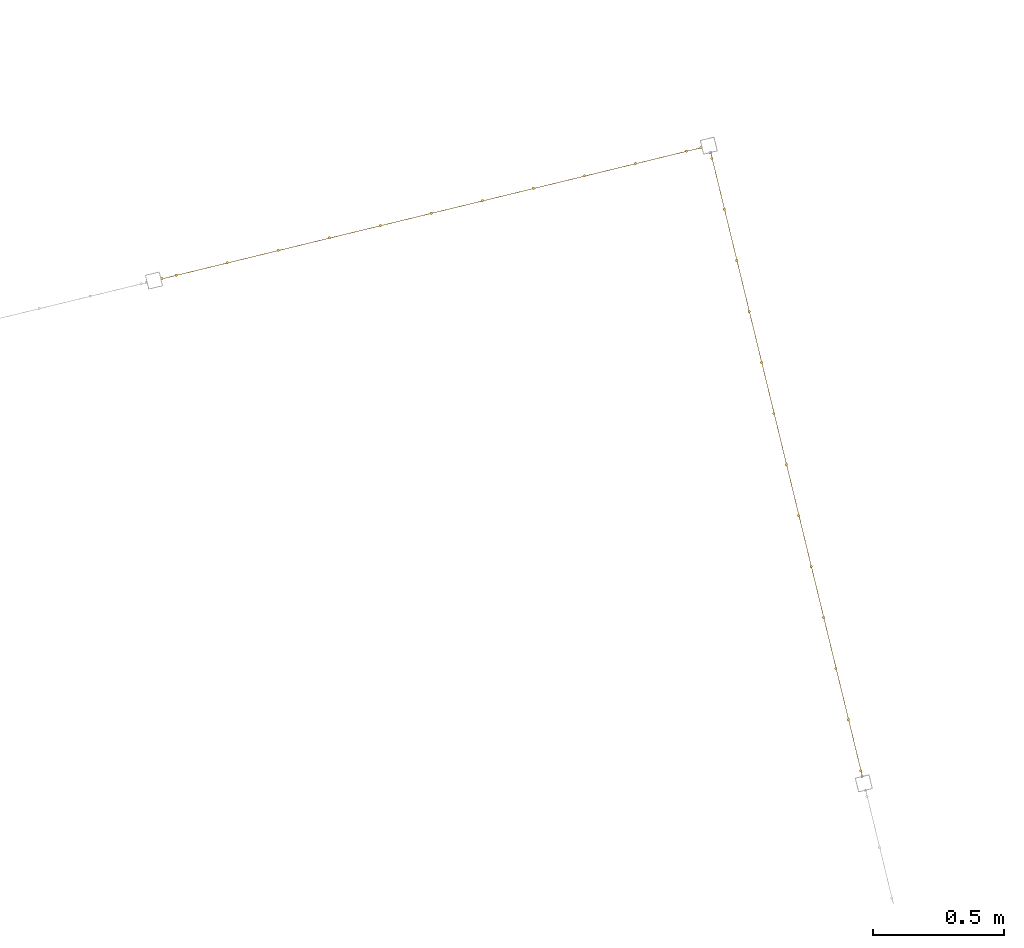
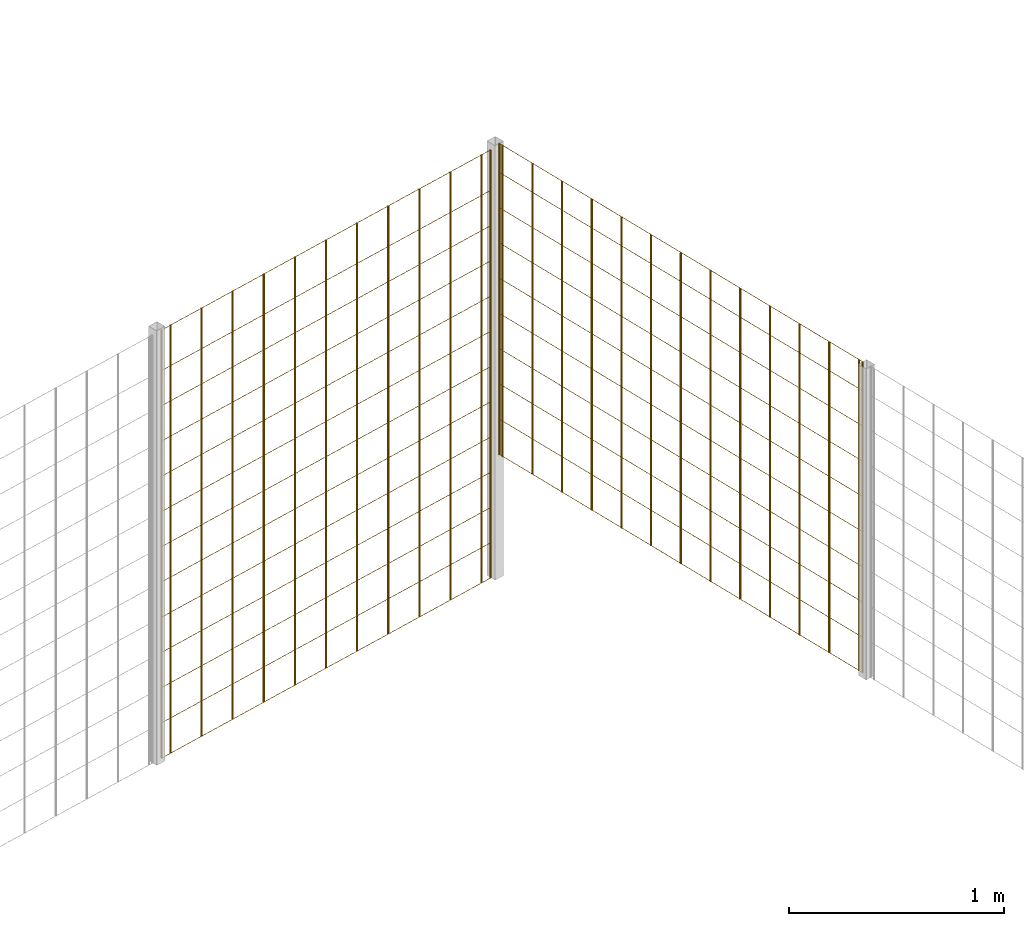
# One storey, part 9 of 10: 2 railings.
"""IFC2X3 building model written with IfcOpenShell, lengths in millimetres."""

from ifc_helpers import new_model, entity, si_unit, converted_unit, derived_unit, direction, frame, origin, origin_2d_with_axis, place, context, subcontext, project, spatial, rectangle, circle, extrude, material, material_list, element, save


model = new_model("IFC2X3")

# Units and contexts
model_context = context("Model", 3, precision=0.01, world=origin(), true_north=direction((6.12303176911189e-17, 1.0)))
body_context = subcontext(model_context, "Body", "Model", "MODEL_VIEW")
ifc_project = project(units=[si_unit("LENGTHUNIT", "METRE", prefix="MILLI"), si_unit("AREAUNIT", "SQUARE_METRE"), si_unit("VOLUMEUNIT", "CUBIC_METRE"), converted_unit("PLANEANGLEUNIT", "DEGREE", entity("IfcRatioMeasure", 0.0174532925199433), si_unit("PLANEANGLEUNIT", "RADIAN"), dimensions=[0, 0, 0, 0, 0, 0, 0]), si_unit("MASSUNIT", "GRAM", prefix="KILO"), derived_unit("MASSDENSITYUNIT", [(si_unit("MASSUNIT", "GRAM", prefix="KILO"), 1), (si_unit("LENGTHUNIT", "METRE"), -3)]), derived_unit("MOMENTOFINERTIAUNIT", [(si_unit("LENGTHUNIT", "METRE"), 4)]), si_unit("TIMEUNIT", "SECOND"), si_unit("FREQUENCYUNIT", "HERTZ"), si_unit("THERMODYNAMICTEMPERATUREUNIT", "DEGREE_CELSIUS"), derived_unit("THERMALTRANSMITTANCEUNIT", [(si_unit("MASSUNIT", "GRAM", prefix="KILO"), 1), (si_unit("THERMODYNAMICTEMPERATUREUNIT", "KELVIN"), -1), (si_unit("TIMEUNIT", "SECOND"), -3)]), derived_unit("VOLUMETRICFLOWRATEUNIT", [(si_unit("LENGTHUNIT", "METRE"), 3), (si_unit("TIMEUNIT", "SECOND"), -1)]), derived_unit("MASSFLOWRATEUNIT", [(si_unit("MASSUNIT", "GRAM", prefix="KILO"), 1), (si_unit("TIMEUNIT", "SECOND"), -1)]), derived_unit("ROTATIONALFREQUENCYUNIT", [(si_unit("TIMEUNIT", "SECOND"), -1)]), si_unit("ELECTRICCURRENTUNIT", "AMPERE"), si_unit("ELECTRICVOLTAGEUNIT", "VOLT"), si_unit("POWERUNIT", "WATT"), si_unit("FORCEUNIT", "NEWTON", prefix="KILO"), si_unit("ILLUMINANCEUNIT", "LUX"), si_unit("LUMINOUSFLUXUNIT", "LUMEN"), si_unit("LUMINOUSINTENSITYUNIT", "CANDELA"), derived_unit("USERDEFINED", [(si_unit("MASSUNIT", "GRAM", prefix="KILO"), -1), (si_unit("LENGTHUNIT", "METRE"), -2), (si_unit("TIMEUNIT", "SECOND"), 3), (si_unit("LUMINOUSFLUXUNIT", "LUMEN"), 1)]), derived_unit("LINEARVELOCITYUNIT", [(si_unit("LENGTHUNIT", "METRE"), 1), (si_unit("TIMEUNIT", "SECOND"), -1)]), si_unit("PRESSUREUNIT", "PASCAL"), derived_unit("USERDEFINED", [(si_unit("LENGTHUNIT", "METRE"), -2), (si_unit("MASSUNIT", "GRAM", prefix="KILO"), 1), (si_unit("TIMEUNIT", "SECOND"), -2)]), derived_unit("LINEARFORCEUNIT", [(si_unit("MASSUNIT", "GRAM", prefix="KILO"), 1), (si_unit("LENGTHUNIT", "METRE"), 1), (si_unit("TIMEUNIT", "SECOND"), -2), (si_unit("LENGTHUNIT", "METRE"), -1)]), derived_unit("PLANARFORCEUNIT", [(si_unit("MASSUNIT", "GRAM", prefix="KILO"), 1), (si_unit("LENGTHUNIT", "METRE"), 1), (si_unit("TIMEUNIT", "SECOND"), -2), (si_unit("LENGTHUNIT", "METRE"), -2)])], contexts=[model_context])

# Site, building, storey
site_placement = place(None, frame((19171.75, -72498.58, 0.0), z_axis=(0.0, 0.0, 1.0), x_axis=(0.971695960795463, 0.236234967296933, 0.0)))
site = spatial("IfcSite", under=ifc_project, at=site_placement, CompositionType="ELEMENT")
building_placement = place(site_placement, origin())
building = spatial("IfcBuilding", under=site, at=building_placement, CompositionType="ELEMENT")
storey_placement = place(building_placement, origin())
storey = spatial("IfcBuildingStorey", under=building, at=storey_placement, Name="01", CompositionType="ELEMENT", Elevation=0.0)

# Railings
ifc_material = material()
ifc_material_list_1 = material_list([ifc_material, ifc_material, ifc_material, ifc_material, ifc_material, ifc_material, ifc_material, ifc_material, ifc_material, ifc_material, ifc_material, ifc_material, ifc_material, ifc_material, ifc_material, ifc_material, ifc_material, ifc_material, ifc_material, ifc_material, ifc_material, ifc_material, ifc_material, ifc_material, ifc_material, ifc_material])
railing_1_placement = place(storey_placement, frame((7724.41, 5593.41, 0.0)))
element("IfcRailing", 1, at=railing_1_placement, inside=storey, material=ifc_material_list_1, PredefinedType="NOTDEFINED", context=body_context, shape_type="SweptSolid", body=[
    extrude(circle(Radius=5.0, at=origin_2d_with_axis()), frame((2063.09, 6.59, 2.0), z_axis=(0.0, 0.0, 1.0), x_axis=(0.0, 1.0, 0.0)), (0.0, 0.0, 1.0), 2428.0),
    extrude(circle(Radius=5.0, at=origin_2d_with_axis()), frame((1863.09, 6.59, 2.0), z_axis=(0.0, 0.0, 1.0), x_axis=(0.0, 1.0, 0.0)), (0.0, 0.0, 1.0), 2428.0),
    extrude(circle(Radius=5.0, at=origin_2d_with_axis()), frame((1663.09, 6.59, 2.0), z_axis=(0.0, 0.0, 1.0), x_axis=(0.0, 1.0, 0.0)), (0.0, 0.0, 1.0), 2428.0),
    extrude(circle(Radius=5.0, at=origin_2d_with_axis()), frame((1463.09, 6.59, 2.0), z_axis=(0.0, 0.0, 1.0), x_axis=(0.0, 1.0, 0.0)), (0.0, 0.0, 1.0), 2428.0),
    extrude(circle(Radius=5.0, at=origin_2d_with_axis()), frame((1263.09, 6.59, 2.0), z_axis=(0.0, 0.0, 1.0), x_axis=(0.0, 1.0, 0.0)), (0.0, 0.0, 1.0), 2428.0),
    extrude(circle(Radius=5.0, at=origin_2d_with_axis()), frame((1063.09, 6.59, 2.0), z_axis=(0.0, 0.0, 1.0), x_axis=(0.0, 1.0, 0.0)), (0.0, 0.0, 1.0), 2428.0),
    extrude(circle(Radius=5.0, at=origin_2d_with_axis()), frame((863.09, 6.59, 2.0), z_axis=(0.0, 0.0, 1.0), x_axis=(0.0, 1.0, 0.0)), (0.0, 0.0, 1.0), 2428.0),
    extrude(circle(Radius=5.0, at=origin_2d_with_axis()), frame((663.09, 6.59, 2.0), z_axis=(0.0, 0.0, 1.0), x_axis=(0.0, 1.0, 0.0)), (0.0, 0.0, 1.0), 2428.0),
    extrude(circle(Radius=5.0, at=origin_2d_with_axis()), frame((463.09, 6.59, 2.0), z_axis=(0.0, 0.0, 1.0), x_axis=(0.0, 1.0, 0.0)), (0.0, 0.0, 1.0), 2428.0),
    extrude(circle(Radius=5.0, at=origin_2d_with_axis()), frame((263.09, 6.59, 2.0), z_axis=(0.0, 0.0, 1.0), x_axis=(0.0, 1.0, 0.0)), (0.0, 0.0, 1.0), 2428.0),
    extrude(circle(Radius=5.0, at=origin_2d_with_axis()), frame((63.09, 6.59, 2.0), z_axis=(0.0, 0.0, 1.0), x_axis=(0.0, 1.0, 0.0)), (0.0, 0.0, 1.0), 2428.0),
    extrude(circle(Radius=5.0, at=origin_2d_with_axis()), frame((2119.59, 6.59, 2.0), z_axis=(0.0, 0.0, 1.0), x_axis=(0.0, 1.0, 0.0)), (0.0, 0.0, 1.0), 2428.0),
    extrude(circle(Radius=5.0, at=origin_2d_with_axis()), frame((6.59, 6.59, 2.0), z_axis=(0.0, 0.0, 1.0), x_axis=(0.0, 1.0, 0.0)), (0.0, 0.0, 1.0), 2428.0),
    extrude(rectangle(XDim=2112.99999999998, YDim=1.99999999999955, at=origin_2d_with_axis()), frame((1063.09, 5.59, 0.0)), (0.0, 0.0, 1.0), 2.00000000000043),
    extrude(rectangle(XDim=2112.99999999998, YDim=1.99999999999955, at=origin_2d_with_axis()), frame((1063.09, 5.59, 200.0)), (0.0, 0.0, 1.0), 2.00000000000043),
    extrude(rectangle(XDim=2112.99999999998, YDim=1.99999999999955, at=origin_2d_with_axis()), frame((1063.09, 5.59, 400.0)), (0.0, 0.0, 1.0), 2.00000000000043),
    extrude(rectangle(XDim=2112.99999999998, YDim=1.99999999999955, at=origin_2d_with_axis()), frame((1063.09, 5.59, 600.0)), (0.0, 0.0, 1.0), 2.00000000000043),
    extrude(rectangle(XDim=2112.99999999998, YDim=1.99999999999955, at=origin_2d_with_axis()), frame((1063.09, 5.59, 800.0)), (0.0, 0.0, 1.0), 2.00000000000036),
    extrude(rectangle(XDim=2112.99999999998, YDim=1.99999999999955, at=origin_2d_with_axis()), frame((1063.09, 5.59, 1000.0)), (0.0, 0.0, 1.0), 2.00000000000036),
    extrude(rectangle(XDim=2112.99999999998, YDim=1.99999999999955, at=origin_2d_with_axis()), frame((1063.09, 5.59, 1200.0)), (0.0, 0.0, 1.0), 2.00000000000036),
    extrude(rectangle(XDim=2112.99999999998, YDim=1.99999999999955, at=origin_2d_with_axis()), frame((1063.09, 5.59, 1400.0)), (0.0, 0.0, 1.0), 2.00000000000036),
    extrude(rectangle(XDim=2112.99999999998, YDim=1.99999999999955, at=origin_2d_with_axis()), frame((1063.09, 5.59, 1600.0)), (0.0, 0.0, 1.0), 2.00000000000036),
    extrude(rectangle(XDim=2112.99999999998, YDim=1.99999999999955, at=origin_2d_with_axis()), frame((1063.09, 5.59, 1800.0)), (0.0, 0.0, 1.0), 2.00000000000036),
    extrude(rectangle(XDim=2112.99999999998, YDim=1.99999999999955, at=origin_2d_with_axis()), frame((1063.09, 5.59, 2000.0)), (0.0, 0.0, 1.0), 2.00000000000036),
    extrude(rectangle(XDim=2112.99999999998, YDim=1.99999999999955, at=origin_2d_with_axis()), frame((1063.09, 5.59, 2200.0)), (0.0, 0.0, 1.0), 2.00000000000036),
    extrude(rectangle(XDim=2112.99999999998, YDim=1.99999999999955, at=origin_2d_with_axis()), frame((1063.09, 5.59, 2430.0)), (0.0, 0.0, 1.0), 2.00000000000036),
])
ifc_material_list_2 = material_list([ifc_material, ifc_material, ifc_material, ifc_material, ifc_material, ifc_material, ifc_material, ifc_material, ifc_material, ifc_material, ifc_material, ifc_material, ifc_material, ifc_material, ifc_material, ifc_material, ifc_material, ifc_material, ifc_material, ifc_material, ifc_material, ifc_material, ifc_material, ifc_material, ifc_material])
railing_2_placement = place(storey_placement, frame((9868.41, 3120.91, 700.0)))
element("IfcRailing", 2, at=railing_2_placement, inside=storey, material=ifc_material_list_2, Name=": 2", ObjectType=": 2", PredefinedType="NOTDEFINED", context=body_context, shape_type="SweptSolid", body=[
    extrude(circle(Radius=5.0, at=origin_2d_with_axis()), frame((6.59, 2429.09, 2.0), z_axis=(0.0, 0.0, 1.0), x_axis=(-1.0, 0.0, 0.0)), (0.0, 0.0, 1.0), 1763.0),
    extrude(circle(Radius=5.0, at=origin_2d_with_axis()), frame((6.59, 2229.09, 2.0), z_axis=(0.0, 0.0, 1.0), x_axis=(-1.0, 0.0, 0.0)), (0.0, 0.0, 1.0), 1763.0),
    extrude(circle(Radius=5.0, at=origin_2d_with_axis()), frame((6.59, 2029.09, 2.0), z_axis=(0.0, 0.0, 1.0), x_axis=(-1.0, 0.0, 0.0)), (0.0, 0.0, 1.0), 1763.0),
    extrude(circle(Radius=5.0, at=origin_2d_with_axis()), frame((6.59, 1829.09, 2.0), z_axis=(0.0, 0.0, 1.0), x_axis=(-1.0, 0.0, 0.0)), (0.0, 0.0, 1.0), 1763.0),
    extrude(circle(Radius=5.0, at=origin_2d_with_axis()), frame((6.59, 1629.09, 2.0), z_axis=(0.0, 0.0, 1.0), x_axis=(-1.0, 0.0, 0.0)), (0.0, 0.0, 1.0), 1763.0),
    extrude(circle(Radius=5.0, at=origin_2d_with_axis()), frame((6.59, 1429.09, 2.0), z_axis=(0.0, 0.0, 1.0), x_axis=(-1.0, 0.0, 0.0)), (0.0, 0.0, 1.0), 1763.0),
    extrude(circle(Radius=5.0, at=origin_2d_with_axis()), frame((6.59, 1229.09, 2.0), z_axis=(0.0, 0.0, 1.0), x_axis=(-1.0, 0.0, 0.0)), (0.0, 0.0, 1.0), 1763.0),
    extrude(circle(Radius=5.0, at=origin_2d_with_axis()), frame((6.59, 1029.09, 2.0), z_axis=(0.0, 0.0, 1.0), x_axis=(-1.0, 0.0, 0.0)), (0.0, 0.0, 1.0), 1763.0),
    extrude(circle(Radius=5.0, at=origin_2d_with_axis()), frame((6.59, 829.09, 2.0), z_axis=(0.0, 0.0, 1.0), x_axis=(-1.0, 0.0, 0.0)), (0.0, 0.0, 1.0), 1763.0),
    extrude(circle(Radius=5.0, at=origin_2d_with_axis()), frame((6.59, 629.09, 2.0), z_axis=(0.0, 0.0, 1.0), x_axis=(-1.0, 0.0, 0.0)), (0.0, 0.0, 1.0), 1763.0),
    extrude(circle(Radius=5.0, at=origin_2d_with_axis()), frame((6.59, 429.09, 2.0), z_axis=(0.0, 0.0, 1.0), x_axis=(-1.0, 0.0, 0.0)), (0.0, 0.0, 1.0), 1763.0),
    extrude(circle(Radius=5.0, at=origin_2d_with_axis()), frame((6.59, 229.09, 2.0), z_axis=(0.0, 0.0, 1.0), x_axis=(-1.0, 0.0, 0.0)), (0.0, 0.0, 1.0), 1763.0),
    extrude(circle(Radius=5.0, at=origin_2d_with_axis()), frame((6.59, 29.09, 2.0), z_axis=(0.0, 0.0, 1.0), x_axis=(-1.0, 0.0, 0.0)), (0.0, 0.0, 1.0), 1763.0),
    extrude(circle(Radius=5.0, at=origin_2d_with_axis()), frame((6.59, 2451.59, 2.0), z_axis=(0.0, 0.0, 1.0), x_axis=(-1.0, 0.0, 0.0)), (0.0, 0.0, 1.0), 1763.0),
    extrude(circle(Radius=5.0, at=origin_2d_with_axis()), frame((6.59, 6.59, 2.0), z_axis=(0.0, 0.0, 1.0), x_axis=(-1.0, 0.0, 0.0)), (0.0, 0.0, 1.0), 1763.0),
    extrude(rectangle(XDim=2445.0, YDim=1.99999999999955, at=origin_2d_with_axis()), frame((7.59, 1229.09, 0.0), z_axis=(0.0, 0.0, 1.0), x_axis=(0.0, 1.0, 0.0)), (0.0, 0.0, 1.0), 2.00000000000036),
    extrude(rectangle(XDim=2445.0, YDim=1.99999999999955, at=origin_2d_with_axis()), frame((7.59, 1229.09, 200.0), z_axis=(0.0, 0.0, 1.0), x_axis=(0.0, 1.0, 0.0)), (0.0, 0.0, 1.0), 2.00000000000036),
    extrude(rectangle(XDim=2445.0, YDim=1.99999999999955, at=origin_2d_with_axis()), frame((7.59, 1229.09, 400.0), z_axis=(0.0, 0.0, 1.0), x_axis=(0.0, 1.0, 0.0)), (0.0, 0.0, 1.0), 2.00000000000036),
    extrude(rectangle(XDim=2445.0, YDim=1.99999999999955, at=origin_2d_with_axis()), frame((7.59, 1229.09, 600.0), z_axis=(0.0, 0.0, 1.0), x_axis=(0.0, 1.0, 0.0)), (0.0, 0.0, 1.0), 2.00000000000036),
    extrude(rectangle(XDim=2445.0, YDim=1.99999999999955, at=origin_2d_with_axis()), frame((7.59, 1229.09, 800.0), z_axis=(0.0, 0.0, 1.0), x_axis=(0.0, 1.0, 0.0)), (0.0, 0.0, 1.0), 2.00000000000036),
    extrude(rectangle(XDim=2445.0, YDim=1.99999999999955, at=origin_2d_with_axis()), frame((7.59, 1229.09, 1000.0), z_axis=(0.0, 0.0, 1.0), x_axis=(0.0, 1.0, 0.0)), (0.0, 0.0, 1.0), 2.00000000000036),
    extrude(rectangle(XDim=2445.0, YDim=1.99999999999955, at=origin_2d_with_axis()), frame((7.59, 1229.09, 1200.0), z_axis=(0.0, 0.0, 1.0), x_axis=(0.0, 1.0, 0.0)), (0.0, 0.0, 1.0), 2.00000000000036),
    extrude(rectangle(XDim=2445.0, YDim=1.99999999999955, at=origin_2d_with_axis()), frame((7.59, 1229.09, 1400.0), z_axis=(0.0, 0.0, 1.0), x_axis=(0.0, 1.0, 0.0)), (0.0, 0.0, 1.0), 2.00000000000036),
    extrude(rectangle(XDim=2445.0, YDim=1.99999999999955, at=origin_2d_with_axis()), frame((7.59, 1229.09, 1600.0), z_axis=(0.0, 0.0, 1.0), x_axis=(0.0, 1.0, 0.0)), (0.0, 0.0, 1.0), 2.00000000000036),
    extrude(rectangle(XDim=2445.0, YDim=1.99999999999955, at=origin_2d_with_axis()), frame((7.59, 1229.09, 1765.0), z_axis=(0.0, 0.0, 1.0), x_axis=(0.0, 1.0, 0.0)), (0.0, 0.0, 1.0), 2.00000000000063),
])

save(model, "model.ifc")
